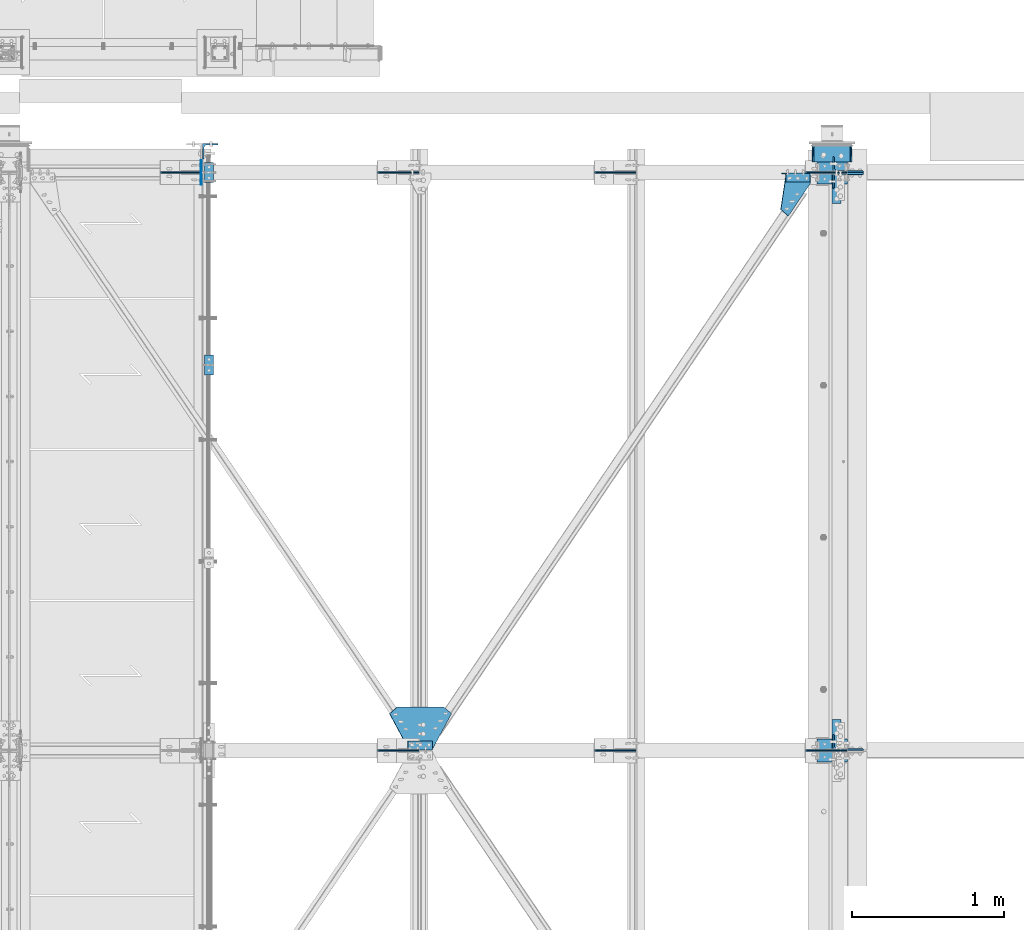
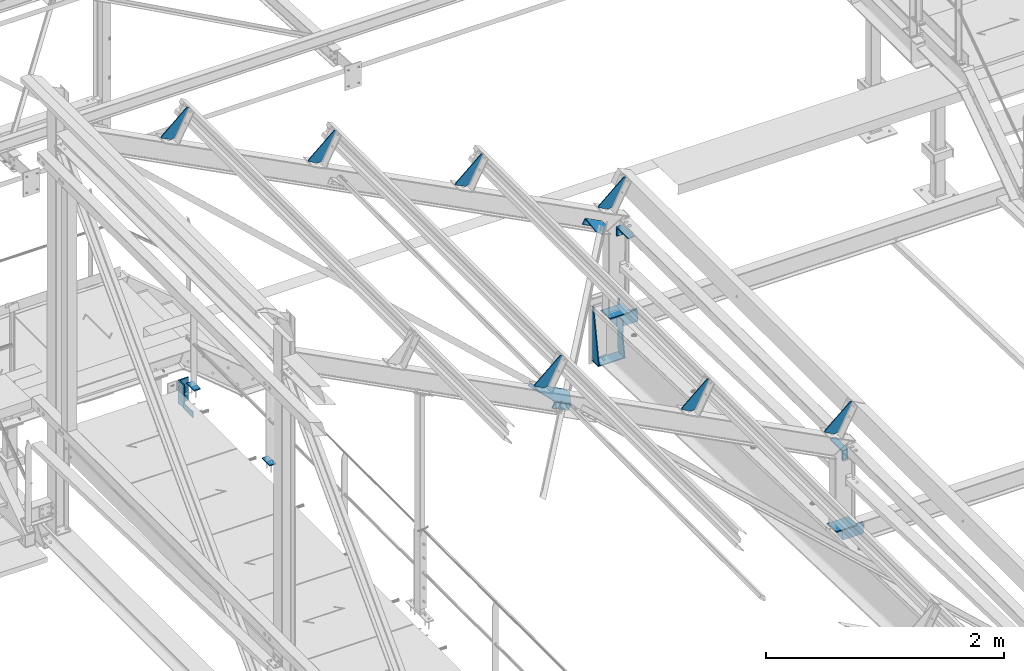
# One storey, part 93 of 496: 20 beams, 5 members, 22 elements without a shape of their own.
"""IFC2X3 building model written with IfcOpenShell, lengths in millimetres."""

from ifc_helpers import new_model, si_unit, frame, origin_with_axes, origin_2d_with_axis, place, context, subcontext, project, spatial, polyline, rectangle, l_section, outline, extrude, material, type_object, element, aggregate, save


model = new_model("IFC2X3")

# Units and contexts
model_context = context("Model", 3, precision=1e-05, world=origin_with_axes())
body_context = subcontext(model_context, "Body", "Model", "MODEL_VIEW")
ifc_project = project(units=[si_unit("LENGTHUNIT", "METRE", prefix="MILLI"), si_unit("AREAUNIT", "SQUARE_METRE"), si_unit("VOLUMEUNIT", "CUBIC_METRE"), si_unit("MASSUNIT", "GRAM", prefix="KILO"), si_unit("TIMEUNIT", "SECOND"), si_unit("PLANEANGLEUNIT", "RADIAN"), si_unit("SOLIDANGLEUNIT", "STERADIAN"), si_unit("THERMODYNAMICTEMPERATUREUNIT", "DEGREE_CELSIUS"), si_unit("LUMINOUSINTENSITYUNIT", "LUMEN")], contexts=[model_context])

# Site, building, storey
site_placement = place(None, origin_with_axes())
site = spatial("IfcSite", under=ifc_project, at=site_placement, CompositionType="ELEMENT")
building_placement = place(site_placement, origin_with_axes())
building = spatial("IfcBuilding", under=site, at=building_placement, Name="Undefined", CompositionType="ELEMENT")
storey_placement = place(building_placement, origin_with_axes())
storey = spatial("IfcBuildingStorey", under=building, at=storey_placement, Name="Undefined", CompositionType="ELEMENT", Elevation=0.0)

# Assembly, beams
assembly_1_placement = place(storey_placement, origin_with_axes())
assembly_1 = element("IfcElementAssembly", 1, at=assembly_1_placement, inside=storey, Name="MAIN COURANTE", AssemblyPlace="NOTDEFINED", PredefinedType="NOTDEFINED")
ifc_material = material(Name="Undefined/S235-E24")
beam_type_1 = type_object("IfcBeamType", PredefinedType="NOTDEFINED")
beam_1_placement = place(assembly_1_placement, frame((24783.9916088087, 15265.0000000346, 8244.99999825157), z_axis=(-1.0, 0.0, 0.0), x_axis=(0.0, -1.0, 0.0)))
beam_1 = element("IfcBeam", 2, at=beam_1_placement, type_object=beam_type_1, material=ifc_material, context=body_context, shape_type="SweptSolid", body=[
    extrude(rectangle(XDim=10.0, YDim=60.0, at=origin_2d_with_axis()), frame((130.0, 0.0, 0.0), z_axis=(-1.0, 0.0, 0.0), x_axis=(0.0, -1.0, 0.0)), (0.0, 0.0, 1.0), 130.0),
])
beam_2_placement = place(assembly_1_placement, frame((24783.9916078373, 14000.0034395757, 8244.99999921276), z_axis=(-1.0, 0.0, 0.0), x_axis=(0.0, -1.0, 0.0)))
beam_2 = element("IfcBeam", 3, at=beam_2_placement, type_object=beam_type_1, material=ifc_material, context=body_context, shape_type="SweptSolid", body=[
    extrude(rectangle(XDim=10.0, YDim=60.0, at=origin_2d_with_axis()), frame((130.0, 0.0, 0.0), z_axis=(-1.0, 0.0, 0.0), x_axis=(0.0, -1.0, 0.0)), (0.0, 0.0, 1.0), 130.0),
])
aggregate(assembly_1, [beam_1, beam_2])

# Assembly, beam
assembly_2_placement = place(storey_placement, origin_with_axes())
assembly_2 = element("IfcElementAssembly", 4, at=assembly_2_placement, inside=storey, Name="TRAVERSE SHED", AssemblyPlace="NOTDEFINED", PredefinedType="NOTDEFINED")
beam_type_2 = type_object("IfcBeamType", PredefinedType="NOTDEFINED")
beam_3_placement = place(assembly_2_placement, frame((28880.0, 11474.8056218445, 7694.39265439492), z_axis=(-1.0, 0.0, 0.0), x_axis=(0.0, -0.999506556345276, 0.031410887010852)))
beam_3 = element("IfcBeam", 5, at=beam_3_placement, type_object=beam_type_2, material=ifc_material, context=body_context, shape_type="SweptSolid", body=[
    extrude(rectangle(XDim=10.0, YDim=200.0, at=origin_2d_with_axis()), frame((149.999995982835, 4.54747350886464e-12, 3.63797880709171e-12), z_axis=(-1.0, 0.0, 0.0), x_axis=(0.0, -1.0, 0.0)), (0.0, 0.0, 1.0), 150.0),
])
aggregate(assembly_2, [beam_3])

assembly_3_placement = place(storey_placement, origin_with_axes())
assembly_3 = element("IfcElementAssembly", 6, at=assembly_3_placement, inside=storey, Name="TRAVERSE SHED", AssemblyPlace="NOTDEFINED", PredefinedType="NOTDEFINED")
beam_4_placement = place(assembly_3_placement, frame((28880.0, 15274.8056218445, 7574.97237948849), z_axis=(-1.0, 0.0, 0.0), x_axis=(0.0, -0.999506556345276, 0.031410887010852)))
beam_4 = element("IfcBeam", 7, at=beam_4_placement, type_object=beam_type_2, material=ifc_material, context=body_context, shape_type="SweptSolid", body=[
    extrude(rectangle(XDim=10.0, YDim=200.0, at=origin_2d_with_axis()), frame((149.999995982835, 4.54747350886464e-12, 3.63797880709171e-12), z_axis=(-1.0, 0.0, 0.0), x_axis=(0.0, -1.0, 0.0)), (0.0, 0.0, 1.0), 150.0),
])
aggregate(assembly_3, [beam_4])

# Assembly, member
assembly_4_placement = place(storey_placement, origin_with_axes())
assembly_4 = element("IfcElementAssembly", 8, at=assembly_4_placement, inside=storey, AssemblyPlace="NOTDEFINED", PredefinedType="NOTDEFINED")
member_type_1 = type_object("IfcMemberType", PredefinedType="NOTDEFINED")
member_1_placement = place(assembly_4_placement, frame((28561.5673650082, 15167.0003434195, 8613.65554132617), z_axis=(0.0, -1.0, 0.0), x_axis=(0.887870970350142, -8.99999576973972e-09, -0.460092534181438)))
member_1 = element("IfcMember", 9, at=member_1_placement, type_object=member_type_1, material=ifc_material, context=body_context, shape_type="SweptSolid", body=[
    extrude(l_section(Depth=60.0, Width=60.0, Thickness=6.0, FilletRadius=8.0, EdgeRadius=4.0, at=origin_2d_with_axis()), frame((180.0, 0.0, 0.0), z_axis=(-1.0, 0.0, 0.0), x_axis=(0.0, -1.0, 0.0)), (0.0, 0.0, 1.0), 180.0),
])
aggregate(assembly_4, [member_1])

assembly_5_placement = place(storey_placement, origin_with_axes())
assembly_5 = element("IfcElementAssembly", 10, at=assembly_5_placement, inside=storey, AssemblyPlace="NOTDEFINED", PredefinedType="NOTDEFINED")
member_2_placement = place(assembly_5_placement, frame((26238.3459314642, 11433.0000991588, 9817.5456013429), z_axis=(0.0, 1.0, 0.0), x_axis=(-0.887870604061621, -1.29999898490562e-08, 0.460093241031915)))
member_2 = element("IfcMember", 11, at=member_2_placement, type_object=member_type_1, material=ifc_material, context=body_context, shape_type="SweptSolid", body=[
    extrude(l_section(Depth=60.0, Width=60.0, Thickness=6.0, FilletRadius=8.0, EdgeRadius=4.0, at=origin_2d_with_axis()), frame((180.0, 0.0, 0.0), z_axis=(-1.0, 0.0, 0.0), x_axis=(0.0, -1.0, 0.0)), (0.0, 0.0, 1.0), 180.0),
])
aggregate(assembly_5, [member_2])

# Assembly, beam
assembly_6_placement = place(storey_placement, origin_with_axes())
assembly_6 = element("IfcElementAssembly", 12, at=assembly_6_placement, inside=storey, Name="SHED", AssemblyPlace="NOTDEFINED", PredefinedType="NOTDEFINED")
beam_type_3 = type_object("IfcBeamType", PredefinedType="NOTDEFINED")
beam_5_placement = place(assembly_6_placement, frame((28714.4895719006, 15200.0, 8721.3758937839), z_axis=(0.0, -1.0, 0.0), x_axis=(-0.460093241820242, 0.0, -0.887870603653112)))
beam_5 = element("IfcBeam", 13, at=beam_5_placement, type_object=beam_type_3, material=ifc_material, context=body_context, shape_type="SweptSolid", body=[
    extrude(outline(polyline([(0.0, 0.0), (20.0, 0.0), (20.0000000002019, 109.999999999982), (-9.99999999974731, 139.99998998623), (-300.0000000002, 139.999893186625), (-300.000000000226, 119.999893186643), (0.0, 0.0)])), frame((0.0, 0.0, -4.0), z_axis=(0.0, 0.0, 1.0), x_axis=(1.0, 0.0, 0.0)), (0.0, 0.0, 1.0), 8.0),
])
aggregate(assembly_6, [beam_5])

assembly_7_placement = place(storey_placement, origin_with_axes())
assembly_7 = element("IfcElementAssembly", 14, at=assembly_7_placement, inside=storey, Name="SHED", AssemblyPlace="NOTDEFINED", PredefinedType="NOTDEFINED")
beam_6_placement = place(assembly_7_placement, frame((27327.8187212, 15200.0, 9439.946688913), z_axis=(0.0, -1.0, 0.0), x_axis=(-0.460093241820242, 0.0, -0.887870603653112)))
beam_6 = element("IfcBeam", 15, at=beam_6_placement, type_object=beam_type_3, material=ifc_material, context=body_context, shape_type="SweptSolid", body=[
    extrude(outline(polyline([(0.0, 0.0), (20.0, 0.0), (20.0000000002019, 109.999999999982), (-9.99999999974731, 139.99998998623), (-300.0000000002, 139.999893186625), (-300.000000000226, 119.999893186643), (0.0, 0.0)])), frame((0.0, 0.0, -4.0), z_axis=(0.0, 0.0, 1.0), x_axis=(1.0, 0.0, 0.0)), (0.0, 0.0, 1.0), 8.0),
])
aggregate(assembly_7, [beam_6])

assembly_8_placement = place(storey_placement, origin_with_axes())
assembly_8 = element("IfcElementAssembly", 16, at=assembly_8_placement, inside=storey, Name="SHED", AssemblyPlace="NOTDEFINED", PredefinedType="NOTDEFINED")
beam_7_placement = place(assembly_8_placement, frame((25901.1937204907, 15200.0, 10179.221665805), z_axis=(0.0, -1.0, 0.0), x_axis=(-0.460093241820242, 0.0, -0.887870603653112)))
beam_7 = element("IfcBeam", 17, at=beam_7_placement, type_object=beam_type_3, material=ifc_material, context=body_context, shape_type="SweptSolid", body=[
    extrude(outline(polyline([(0.0, 0.0), (20.0, 0.0), (20.0000000002019, 109.999999999982), (-9.99999999974731, 139.99998998623), (-300.0000000002, 139.999893186625), (-300.000000000226, 119.999893186643), (0.0, 0.0)])), frame((0.0, 0.0, -4.0), z_axis=(0.0, 0.0, 1.0), x_axis=(1.0, 0.0, 0.0)), (0.0, 0.0, 1.0), 8.0),
])
aggregate(assembly_8, [beam_7])

assembly_9_placement = place(storey_placement, origin_with_axes())
assembly_9 = element("IfcElementAssembly", 18, at=assembly_9_placement, inside=storey, Name="SHED", AssemblyPlace="NOTDEFINED", PredefinedType="NOTDEFINED")
beam_8_placement = place(assembly_9_placement, frame((24474.5687197833, 15200.0, 10918.4966426993), z_axis=(0.0, -1.0, 0.0), x_axis=(-0.460093241820242, 0.0, -0.887870603653112)))
beam_8 = element("IfcBeam", 19, at=beam_8_placement, type_object=beam_type_3, material=ifc_material, context=body_context, shape_type="SweptSolid", body=[
    extrude(outline(polyline([(0.0, 0.0), (20.0, 0.0), (20.0000000002019, 109.999999999982), (-9.99999999974731, 139.99998998623), (-300.0000000002, 139.999893186625), (-300.000000000226, 119.999893186643), (0.0, 0.0)])), frame((0.0, 0.0, -4.0), z_axis=(0.0, 0.0, 1.0), x_axis=(1.0, 0.0, 0.0)), (0.0, 0.0, 1.0), 8.0),
])
aggregate(assembly_9, [beam_8])

assembly_10_placement = place(storey_placement, origin_with_axes())
assembly_10 = element("IfcElementAssembly", 20, at=assembly_10_placement, inside=storey, Name="SHED", AssemblyPlace="NOTDEFINED", PredefinedType="NOTDEFINED")
beam_9_placement = place(assembly_10_placement, frame((28714.4895719006, 11400.0, 8721.3758937839), z_axis=(0.0, -1.0, 0.0), x_axis=(-0.460093241820242, 0.0, -0.887870603653112)))
beam_9 = element("IfcBeam", 21, at=beam_9_placement, type_object=beam_type_3, material=ifc_material, context=body_context, shape_type="SweptSolid", body=[
    extrude(outline(polyline([(0.0, 0.0), (20.0, 0.0), (20.0000000002019, 109.999999999982), (-9.99999999974731, 139.99998998623), (-300.0000000002, 139.999893186625), (-300.000000000226, 119.999893186643), (0.0, 0.0)])), frame((0.0, 0.0, -4.0), z_axis=(0.0, 0.0, 1.0), x_axis=(1.0, 0.0, 0.0)), (0.0, 0.0, 1.0), 8.0),
])
aggregate(assembly_10, [beam_9])

assembly_11_placement = place(storey_placement, origin_with_axes())
assembly_11 = element("IfcElementAssembly", 22, at=assembly_11_placement, inside=storey, Name="SHED", AssemblyPlace="NOTDEFINED", PredefinedType="NOTDEFINED")
beam_10_placement = place(assembly_11_placement, frame((27327.8187212, 11400.0, 9439.946688913), z_axis=(0.0, -1.0, 0.0), x_axis=(-0.460093241820242, 0.0, -0.887870603653112)))
beam_10 = element("IfcBeam", 23, at=beam_10_placement, type_object=beam_type_3, material=ifc_material, context=body_context, shape_type="SweptSolid", body=[
    extrude(outline(polyline([(0.0, 0.0), (20.0, 0.0), (20.0000000002019, 109.999999999982), (-9.99999999974731, 139.99998998623), (-300.0000000002, 139.999893186625), (-300.000000000226, 119.999893186643), (0.0, 0.0)])), frame((0.0, 0.0, -4.0), z_axis=(0.0, 0.0, 1.0), x_axis=(1.0, 0.0, 0.0)), (0.0, 0.0, 1.0), 8.0),
])
aggregate(assembly_11, [beam_10])

assembly_12_placement = place(storey_placement, origin_with_axes())
assembly_12 = element("IfcElementAssembly", 24, at=assembly_12_placement, inside=storey, Name="SHED", AssemblyPlace="NOTDEFINED", PredefinedType="NOTDEFINED")
beam_11_placement = place(assembly_12_placement, frame((25901.1937204907, 11400.0, 10179.221665805), z_axis=(0.0, -1.0, 0.0), x_axis=(-0.460093241820242, 0.0, -0.887870603653112)))
beam_11 = element("IfcBeam", 25, at=beam_11_placement, type_object=beam_type_3, material=ifc_material, context=body_context, shape_type="SweptSolid", body=[
    extrude(outline(polyline([(0.0, 0.0), (20.0, 0.0), (20.0000000002019, 109.999999999982), (-9.99999999974731, 139.99998998623), (-300.0000000002, 139.999893186625), (-300.000000000226, 119.999893186643), (0.0, 0.0)])), frame((0.0, 0.0, -4.0), z_axis=(0.0, 0.0, 1.0), x_axis=(1.0, 0.0, 0.0)), (0.0, 0.0, 1.0), 8.0),
])
aggregate(assembly_12, [beam_11])

assembly_13_placement = place(storey_placement, origin_with_axes())
assembly_13 = element("IfcElementAssembly", 26, at=assembly_13_placement, inside=storey, AssemblyPlace="NOTDEFINED", PredefinedType="NOTDEFINED")
beam_type_4 = type_object("IfcBeamType", PredefinedType="NOTDEFINED")
beam_12_placement = place(assembly_13_placement, frame((28541.9892757663, 14957.1141329509, 8660.96851491176), z_axis=(0.460093364927087, 0.0, 0.887870539859315), x_axis=(0.706117063313599, -0.606225551624848, -0.365908832162506)))
beam_12 = element("IfcBeam", 27, at=beam_12_placement, type_object=beam_type_4, material=ifc_material, context=body_context, shape_type="SweptSolid", body=[
    extrude(outline(polyline([(0.0, 0.0), (70.0, 0.0), (70.0000000011751, 269.669891357869), (34.9265289317609, 315.681945801189), (-108.226165771541, 206.561325072886), (0.0, 0.0)])), frame((0.0, 0.0, -3.0), z_axis=(0.0, 0.0, 1.0), x_axis=(1.0, 0.0, 0.0)), (0.0, 0.0, 1.0), 6.0),
])
aggregate(assembly_13, [beam_12])

# Assembly, member
assembly_14_placement = place(storey_placement, origin_with_axes())
assembly_14 = element("IfcElementAssembly", 28, at=assembly_14_placement, inside=storey, AssemblyPlace="NOTDEFINED", PredefinedType="NOTDEFINED")
member_type_2 = type_object("IfcMemberType", PredefinedType="NOTDEFINED")
member_3_placement = place(assembly_14_placement, frame((28986.0000000001, 15251.0896210785, 7410.63663406438), z_axis=(1.0, 0.0, 0.0), x_axis=(0.0, 0.031410887010906, 0.999506556345274)))
member_3 = element("IfcMember", 29, at=member_3_placement, type_object=member_type_2, material=ifc_material, context=body_context, shape_type="SweptSolid", body=[
    extrude(l_section(Depth=200.0, Width=100.0, Thickness=10.0, FilletRadius=15.0, EdgeRadius=7.5, at=origin_2d_with_axis()), frame((120.0, 0.0, 0.0), z_axis=(-1.0, 0.0, 0.0), x_axis=(0.0, -1.0, 0.0)), (0.0, 0.0, 1.0), 120.0),
])
aggregate(assembly_14, [member_3])

assembly_15_placement = place(storey_placement, origin_with_axes())
assembly_15 = element("IfcElementAssembly", 30, at=assembly_15_placement, inside=storey, AssemblyPlace="NOTDEFINED", PredefinedType="NOTDEFINED")
member_4_placement = place(assembly_15_placement, frame((28986.0000000001, 15148.9104115117, 7533.90703577274), z_axis=(1.0, 0.0, 0.0), x_axis=(0.0, -0.031410887010906, -0.999506556345274)))
member_4 = element("IfcMember", 31, at=member_4_placement, type_object=member_type_2, material=ifc_material, context=body_context, shape_type="SweptSolid", body=[
    extrude(l_section(Depth=200.0, Width=100.0, Thickness=10.0, FilletRadius=15.0, EdgeRadius=7.5, at=origin_2d_with_axis()), frame((120.0, 0.0, 0.0), z_axis=(-1.0, 0.0, 0.0), x_axis=(0.0, -1.0, 0.0)), (0.0, 0.0, 1.0), 120.0),
])
aggregate(assembly_15, [member_4])

assembly_16_placement = place(storey_placement, origin_with_axes())
assembly_16 = element("IfcElementAssembly", 32, at=assembly_16_placement, inside=storey, AssemblyPlace="NOTDEFINED", PredefinedType="NOTDEFINED")
member_5_placement = place(assembly_16_placement, frame((28986.0000000001, 11451.0896058186, 7530.05644607517), z_axis=(1.0, 0.0, 0.0), x_axis=(0.0, 0.031410887010906, 0.999506556345274)))
member_5 = element("IfcMember", 33, at=member_5_placement, type_object=member_type_2, material=ifc_material, context=body_context, shape_type="SweptSolid", body=[
    extrude(l_section(Depth=200.0, Width=100.0, Thickness=10.0, FilletRadius=15.0, EdgeRadius=7.5, at=origin_2d_with_axis()), frame((120.0, 0.0, 0.0), z_axis=(-1.0, 0.0, 0.0), x_axis=(0.0, -1.0, 0.0)), (0.0, 0.0, 1.0), 120.0),
])
aggregate(assembly_16, [member_5])

# Assembly, beam
assembly_17_placement = place(storey_placement, origin_with_axes())
assembly_17 = element("IfcElementAssembly", 34, at=assembly_17_placement, inside=storey, AssemblyPlace="NOTDEFINED", PredefinedType="NOTDEFINED")
beam_type_5 = type_object("IfcBeamType", PredefinedType="NOTDEFINED")
beam_13_placement = place(assembly_17_placement, frame((28880.0, 15096.5, 8400.0), z_axis=(0.0, -1.0, 0.0), x_axis=(1.0, 0.0, 0.0)))
beam_13 = element("IfcBeam", 35, at=beam_13_placement, type_object=beam_type_5, material=ifc_material, context=body_context, shape_type="SweptSolid", body=[
    extrude(l_section(Depth=200.0, Width=100.0, Thickness=10.0, FilletRadius=15.0, EdgeRadius=7.5, at=origin_2d_with_axis()), frame((60.0, 0.0, 0.0), z_axis=(-1.0, 0.0, 0.0), x_axis=(0.0, -1.0, 0.0)), (0.0, 0.0, 1.0), 60.0),
])
aggregate(assembly_17, [beam_13])

assembly_18_placement = place(storey_placement, origin_with_axes())
assembly_18 = element("IfcElementAssembly", 36, at=assembly_18_placement, inside=storey, AssemblyPlace="NOTDEFINED", PredefinedType="NOTDEFINED")
beam_14_placement = place(assembly_18_placement, frame((28940.0, 11503.5, 8400.0), z_axis=(0.0, 1.0, 0.0), x_axis=(-1.0, 0.0, 0.0)))
beam_14 = element("IfcBeam", 37, at=beam_14_placement, type_object=beam_type_5, material=ifc_material, context=body_context, shape_type="SweptSolid", body=[
    extrude(l_section(Depth=200.0, Width=100.0, Thickness=10.0, FilletRadius=15.0, EdgeRadius=7.5, at=origin_2d_with_axis()), frame((60.0, 0.0, 0.0), z_axis=(-1.0, 0.0, 0.0), x_axis=(0.0, -1.0, 0.0)), (0.0, 0.0, 1.0), 60.0),
])
aggregate(assembly_18, [beam_14])

assembly_19_placement = place(storey_placement, origin_with_axes())
assembly_19 = element("IfcElementAssembly", 38, at=assembly_19_placement, inside=storey, AssemblyPlace="NOTDEFINED", PredefinedType="NOTDEFINED")
beam_type_6 = type_object("IfcBeamType", PredefinedType="NOTDEFINED")
beam_15_placement = place(assembly_19_placement, frame((24732.9916006456, 15120.0, 7985.0), z_axis=(-1.0, 0.0, 0.0), x_axis=(0.0, 0.0, 1.0)))
beam_15 = element("IfcBeam", 39, at=beam_15_placement, type_object=beam_type_6, material=ifc_material, context=body_context, shape_type="SweptSolid", body=[
    extrude(outline(polyline([(0.0, 0.0), (60.0, 0.0), (60.0, 159.999984741211), (0.0, 159.999984741211), (0.0, 0.0)])), frame((0.0, 0.0, -3.0), z_axis=(0.0, 0.0, 1.0), x_axis=(1.0, 0.0, 0.0)), (0.0, 0.0, 1.0), 6.0),
])
aggregate(assembly_19, [beam_15])

assembly_20_placement = place(storey_placement, origin_with_axes())
assembly_20 = element("IfcElementAssembly", 40, at=assembly_20_placement, inside=storey, AssemblyPlace="NOTDEFINED", PredefinedType="NOTDEFINED")
beam_type_7 = type_object("IfcBeamType", PredefinedType="NOTDEFINED")
beam_16_placement = place(assembly_20_placement, frame((26253.52894678, 11413.0000019657, 9846.84543829438), z_axis=(-0.460093241820242, 0.0, -0.887870603653112), x_axis=(-0.887870604061621, -1.29999898490562e-08, 0.460093241031915)))
beam_16 = element("IfcBeam", 41, at=beam_16_placement, type_object=beam_type_7, material=ifc_material, context=body_context, shape_type="SweptSolid", body=[
    extrude(outline(polyline([(0.0, 0.0), (180.000000001455, -5.27506927028298e-10), (319.15396118478, 229.886291503941), (263.483459475512, 272.322082519409), (-83.481330871291, 272.322082518416), (-139.151824951412, 229.88630676142), (0.0, 0.0)])), frame((0.0, 0.0, -3.0), z_axis=(0.0, 0.0, 1.0), x_axis=(1.0, 0.0, 0.0)), (0.0, 0.0, 1.0), 6.0),
])
aggregate(assembly_20, [beam_16])

assembly_21_placement = place(storey_placement, origin_with_axes())
assembly_21 = element("IfcElementAssembly", 42, at=assembly_21_placement, inside=storey, AssemblyPlace="NOTDEFINED", PredefinedType="NOTDEFINED")
beam_type_8 = type_object("IfcBeamType", PredefinedType="NOTDEFINED")
beam_17_placement = place(assembly_21_placement, frame((24792.491600645, 15339.9999999023, 8210.00437164958), z_axis=(1.0, 0.0, 0.0), x_axis=(0.0, 0.0, -1.0)))
beam_17 = element("IfcBeam", 43, at=beam_17_placement, type_object=beam_type_8, material=ifc_material, context=body_context, shape_type="SweptSolid", body=[
    extrude(l_section(Depth=100.0, Width=100.0, Thickness=10.0, FilletRadius=12.0, EdgeRadius=6.0, at=origin_2d_with_axis()), frame((240.0, 0.0, 0.0), z_axis=(-1.0, 0.0, 0.0), x_axis=(0.0, -1.0, 0.0)), (0.0, 0.0, 1.0), 240.0),
])
aggregate(assembly_21, [beam_17])

# Assembly, beams
assembly_22_placement = place(storey_placement, origin_with_axes())
assembly_22 = element("IfcElementAssembly", 44, at=assembly_22_placement, inside=storey, AssemblyPlace="NOTDEFINED", PredefinedType="NOTDEFINED")
beam_type_9 = type_object("IfcBeamType", PredefinedType="NOTDEFINED")
beam_18_placement = place(assembly_22_placement, frame((28755.0000000018, 15270.042093467, 7019.84807001334), z_axis=(-1.0, 0.0, 0.0), x_axis=(0.0, 0.031410887010906, 0.999506556345274)))
beam_18 = element("IfcBeam", 45, at=beam_18_placement, type_object=beam_type_9, material=ifc_material, context=body_context, shape_type="SweptSolid", body=[
    extrude(outline(polyline([(0.0, 0.0), (20.0, 0.0), (547.705993651307, 72.789970396836), (548.334167479413, 92.780097960278), (29.9851968664639, 109.069869088122), (3.83439057142213e-08, 80.0121917722809), (0.0, 0.0)])), frame((0.0, 0.0, -5.0), z_axis=(0.0, 0.0, 1.0), x_axis=(1.0, 0.0, 0.0)), (0.0, 0.0, 1.0), 10.0),
])
beam_19_placement = place(assembly_22_placement, frame((29004.9999999936, 15270.042093468, 7019.84807001335), z_axis=(-1.0, 0.0, 0.0), x_axis=(0.0, 0.031410887010906, 0.999506556345274)))
beam_19 = element("IfcBeam", 46, at=beam_19_placement, type_object=beam_type_9, material=ifc_material, context=body_context, shape_type="SweptSolid", body=[
    extrude(outline(polyline([(0.0, 0.0), (20.0, 0.0), (547.705993651307, 72.789970396836), (548.334167479413, 92.780097960278), (29.9851968664639, 109.069869088122), (3.83439057142213e-08, 80.0121917722809), (0.0, 0.0)])), frame((0.0, 0.0, -5.0), z_axis=(0.0, 0.0, 1.0), x_axis=(1.0, 0.0, 0.0)), (0.0, 0.0, 1.0), 10.0),
])
beam_type_10 = type_object("IfcBeamType", PredefinedType="NOTDEFINED")
beam_20_placement = place(assembly_22_placement, frame((28879.9999999999, 15379.8429462114, 7011.39497068424), z_axis=(-1.0, 0.0, 0.0), x_axis=(0.0, -0.999506556345276, 0.031410887010852)))
beam_20 = element("IfcBeam", 47, at=beam_20_placement, type_object=beam_type_10, material=ifc_material, context=body_context, shape_type="SweptSolid", body=[
    extrude(rectangle(XDim=10.0, YDim=260.0, at=origin_2d_with_axis()), frame((110.012190922962, 0.0, 0.0), z_axis=(-1.0, 0.0, 0.0), x_axis=(0.0, -1.0, 0.0)), (0.0, 0.0, 1.0), 110.01),
])
aggregate(assembly_22, [beam_18, beam_19, beam_20])

save(model, "model.ifc")
